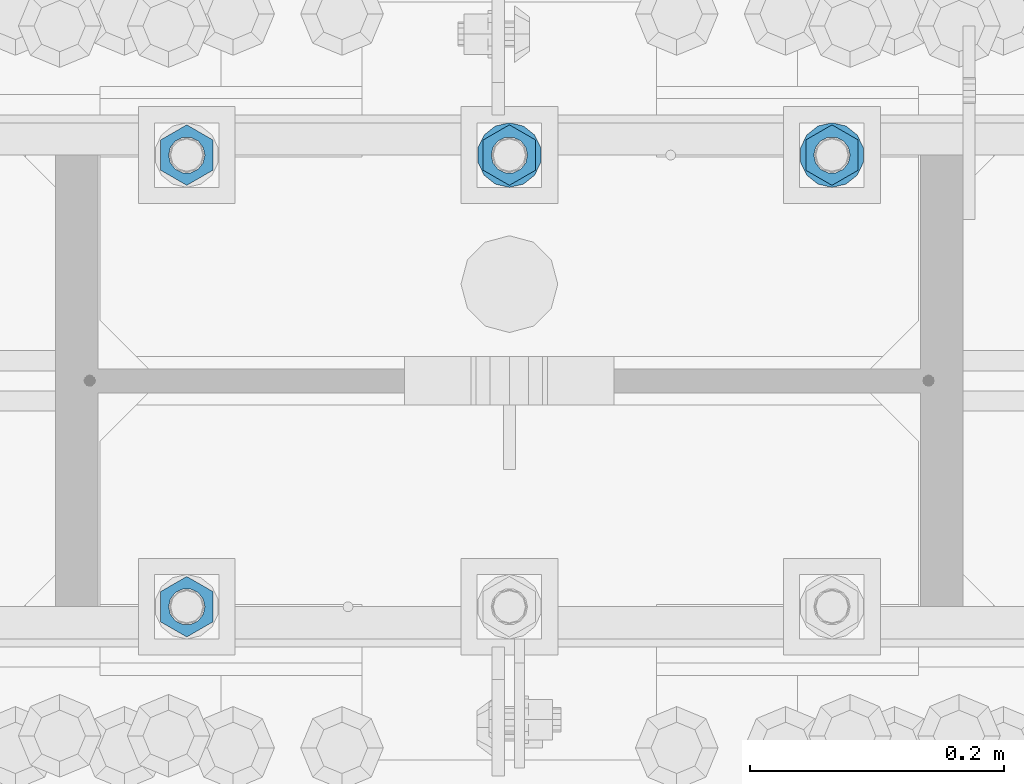
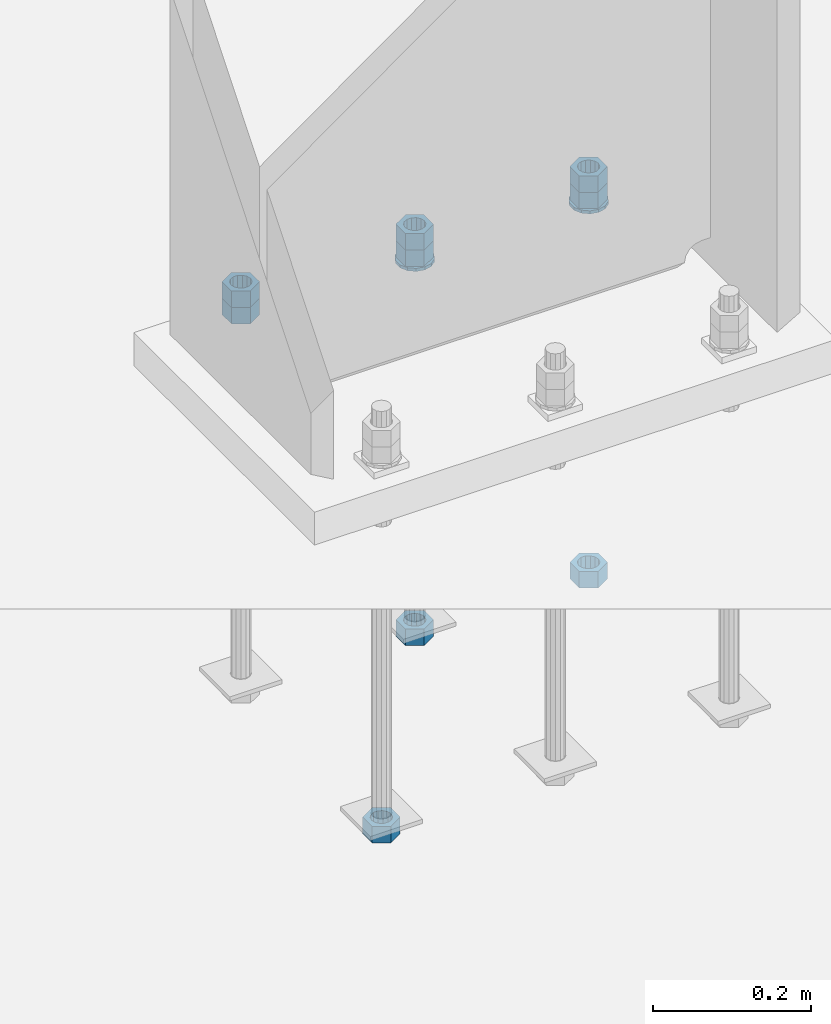
# One storey, part 1023 of 1763: 11 columns, 1 element without a shape of its own.
"""IFC2X3 building model written with IfcOpenShell, lengths in millimetres."""

from ifc_helpers import new_model, si_unit, frame, origin_with_axes, place, context, subcontext, project, spatial, faceted_brep, material, type_object, element, aggregate, save


model = new_model("IFC2X3")

# Units and contexts
model_context = context("Model", 3, precision=1e-05, world=origin_with_axes())
body_context = subcontext(model_context, "Body", "Model", "MODEL_VIEW")
ifc_project = project(units=[si_unit("LENGTHUNIT", "METRE", prefix="MILLI"), si_unit("AREAUNIT", "SQUARE_METRE"), si_unit("VOLUMEUNIT", "CUBIC_METRE"), si_unit("MASSUNIT", "GRAM", prefix="KILO"), si_unit("TIMEUNIT", "SECOND"), si_unit("PLANEANGLEUNIT", "RADIAN"), si_unit("SOLIDANGLEUNIT", "STERADIAN"), si_unit("THERMODYNAMICTEMPERATUREUNIT", "DEGREE_CELSIUS"), si_unit("LUMINOUSINTENSITYUNIT", "LUMEN")], contexts=[model_context])

# Site, building, storey
site_placement = place(None, origin_with_axes())
site = spatial("IfcSite", under=ifc_project, at=site_placement, CompositionType="ELEMENT")
building_placement = place(site_placement, origin_with_axes())
building = spatial("IfcBuilding", under=site, at=building_placement, Name="Undefined", CompositionType="ELEMENT")
storey_placement = place(building_placement, origin_with_axes())
storey = spatial("IfcBuildingStorey", under=building, at=storey_placement, Name="Undefined", CompositionType="ELEMENT", Elevation=0.0)

# Assembly, columns
assembly_placement = place(storey_placement, origin_with_axes())
assembly = element("IfcElementAssembly", 1, at=assembly_placement, inside=storey, Name="TEMPLATE", AssemblyPlace="NOTDEFINED", PredefinedType="RIGID_FRAME")
ifc_material_1 = material(Name="STEEL/A563")
column_type_1 = type_object("IfcColumnType", Name="1_HEAVY_HEX_NUT", PredefinedType="NOTDEFINED")
column_1_placement = place(assembly_placement, frame((-61340.4372736983, 52298.6, -150.812499999996), z_axis=(-1.0, 0.0, 0.0), x_axis=(0.0, 0.0, -1.0)))
column_1 = element("IfcColumn", 2, at=column_1_placement, type_object=column_type_1, material=ifc_material_1, Name="NUT", ObjectType="1_HEAVY_HEX_NUT", context=body_context, shape_type="Brep", body=[
    faceted_brep([(0.0, -23.8099994659424, 0.0), (0.0, -11.9099998474121, -20.6200008392334), (25.4, -11.9099998474121, -20.6200008392334), (25.4, -23.8099994659424, 0.0), (0.0, 11.9099998474121, -20.6200008392334), (25.4, 11.9099998474121, -20.6200008392334), (0.0, 23.8099994659424, 0.0), (25.4, 23.8099994659424, 0.0), (0.0, 11.9099998474121, 20.6200008392334), (25.4, 11.9099998474121, 20.6200008392334), (0.0, -11.9099998474121, 20.6200008392334), (25.4, -11.9099998474121, 20.6200008392334), (0.0, 0.0, 14.289999961853), (0.0, 6.20019861543551, 12.8748450879575), (25.4, 6.20019861543551, 12.8748450879502), (25.4, 0.0, 14.289999961853), (0.0, 11.1723718546418, 8.90966924477834), (25.4, 11.1723718546418, 8.90966924477834), (0.0, 13.9317198278877, 3.17982413774735), (25.4, 13.9317198278877, 3.17982413774007), (0.0, 13.9317198278877, -3.17982413774735), (25.4, 13.9317198278877, -3.17982413774007), (0.0, 11.1723718546418, -8.90966924477834), (25.4, 11.1723718546418, -8.90966924477834), (0.0, 6.20019861543551, -12.8748450879575), (25.4, 6.20019861543551, -12.8748450879502), (0.0, 0.0, -14.289999961853), (25.4, 0.0, -14.289999961853), (0.0, -6.20019861543551, -12.8748450879575), (25.4, -6.20019861543551, -12.8748450879502), (0.0, -11.1723718546418, -8.90966924477834), (25.4, -11.1723718546418, -8.90966924477834), (0.0, -13.9317198278877, -3.17982413774735), (25.4, -13.9317198278877, -3.17982413774007), (0.0, -13.9317198278877, 3.17982413774735), (25.4, -13.9317198278877, 3.17982413774007), (0.0, -11.1723718546418, 8.90966924477834), (25.4, -11.1723718546418, 8.90966924477834), (0.0, -6.20019861543551, 12.8748450879575), (25.4, -6.20019861543551, 12.8748450879502)], [[[0, 1, 2, 3]], [[1, 4, 5, 2]], [[4, 6, 7, 5]], [[6, 8, 9, 7]], [[8, 10, 11, 9]], [[10, 0, 3, 11]], [[12, 13, 14, 15]], [[13, 16, 17, 14]], [[16, 18, 19, 17]], [[18, 20, 21, 19]], [[20, 22, 23, 21]], [[22, 24, 25, 23]], [[24, 26, 27, 25]], [[26, 28, 29, 27]], [[28, 30, 31, 29]], [[30, 32, 33, 31]], [[32, 34, 35, 33]], [[34, 36, 37, 35]], [[36, 38, 39, 37]], [[38, 12, 15, 39]], [[5, 7, 9, 11, 3, 2], [17, 19, 21, 23, 25, 27, 29, 31, 33, 35, 37, 39, 15, 14]], [[10, 8, 6, 4, 1, 0], [38, 36, 34, 32, 30, 28, 26, 24, 22, 20, 18, 16, 13, 12]]]),
])
column_2_placement = place(assembly_placement, frame((-61594.4372736983, 52298.6, -150.812499999996), z_axis=(-1.0, 0.0, 0.0), x_axis=(0.0, 0.0, -1.0)))
column_2 = element("IfcColumn", 3, at=column_2_placement, type_object=column_type_1, material=ifc_material_1, Name="NUT", ObjectType="1_HEAVY_HEX_NUT", context=body_context, shape_type="Brep", body=[
    faceted_brep([(0.0, -23.8099994659424, 0.0), (0.0, -11.9099998474121, -20.6200008392334), (25.4, -11.9099998474121, -20.6200008392334), (25.4, -23.8099994659424, 0.0), (0.0, 11.9099998474121, -20.6200008392334), (25.4, 11.9099998474121, -20.6200008392334), (0.0, 23.8099994659424, 0.0), (25.4, 23.8099994659424, 0.0), (0.0, 11.9099998474121, 20.6200008392334), (25.4, 11.9099998474121, 20.6200008392334), (0.0, -11.9099998474121, 20.6200008392334), (25.4, -11.9099998474121, 20.6200008392334), (0.0, 0.0, 14.289999961853), (0.0, 6.20019861543551, 12.8748450879575), (25.4, 6.20019861543551, 12.8748450879502), (25.4, 0.0, 14.289999961853), (0.0, 11.1723718546418, 8.90966924477834), (25.4, 11.1723718546418, 8.90966924477834), (0.0, 13.9317198278877, 3.17982413774735), (25.4, 13.9317198278877, 3.17982413774007), (0.0, 13.9317198278877, -3.17982413774735), (25.4, 13.9317198278877, -3.17982413774007), (0.0, 11.1723718546418, -8.90966924477834), (25.4, 11.1723718546418, -8.90966924477834), (0.0, 6.20019861543551, -12.8748450879575), (25.4, 6.20019861543551, -12.8748450879502), (0.0, 0.0, -14.289999961853), (25.4, 0.0, -14.289999961853), (0.0, -6.20019861543551, -12.8748450879575), (25.4, -6.20019861543551, -12.8748450879502), (0.0, -11.1723718546418, -8.90966924477834), (25.4, -11.1723718546418, -8.90966924477834), (0.0, -13.9317198278877, -3.17982413774735), (25.4, -13.9317198278877, -3.17982413774007), (0.0, -13.9317198278877, 3.17982413774735), (25.4, -13.9317198278877, 3.17982413774007), (0.0, -11.1723718546418, 8.90966924477834), (25.4, -11.1723718546418, 8.90966924477834), (0.0, -6.20019861543551, 12.8748450879575), (25.4, -6.20019861543551, 12.8748450879502)], [[[0, 1, 2, 3]], [[1, 4, 5, 2]], [[4, 6, 7, 5]], [[6, 8, 9, 7]], [[8, 10, 11, 9]], [[10, 0, 3, 11]], [[12, 13, 14, 15]], [[13, 16, 17, 14]], [[16, 18, 19, 17]], [[18, 20, 21, 19]], [[20, 22, 23, 21]], [[22, 24, 25, 23]], [[24, 26, 27, 25]], [[26, 28, 29, 27]], [[28, 30, 31, 29]], [[30, 32, 33, 31]], [[32, 34, 35, 33]], [[34, 36, 37, 35]], [[36, 38, 39, 37]], [[38, 12, 15, 39]], [[5, 7, 9, 11, 3, 2], [17, 19, 21, 23, 25, 27, 29, 31, 33, 35, 37, 39, 15, 14]], [[10, 8, 6, 4, 1, 0], [38, 36, 34, 32, 30, 28, 26, 24, 22, 20, 18, 16, 13, 12]]]),
])
column_3_placement = place(assembly_placement, frame((-61848.4372736983, 52298.6, -150.812499999996), z_axis=(-1.0, 0.0, 0.0), x_axis=(0.0, 0.0, -1.0)))
column_3 = element("IfcColumn", 4, at=column_3_placement, type_object=column_type_1, material=ifc_material_1, Name="NUT", ObjectType="1_HEAVY_HEX_NUT", context=body_context, shape_type="Brep", body=[
    faceted_brep([(0.0, -23.8099994659424, 0.0), (0.0, -11.9099998474121, -20.6200008392334), (25.4, -11.9099998474121, -20.6200008392334), (25.4, -23.8099994659424, 0.0), (0.0, 11.9099998474121, -20.6200008392334), (25.4, 11.9099998474121, -20.6200008392334), (0.0, 23.8099994659424, 0.0), (25.4, 23.8099994659424, 0.0), (0.0, 11.9099998474121, 20.6200008392334), (25.4, 11.9099998474121, 20.6200008392334), (0.0, -11.9099998474121, 20.6200008392334), (25.4, -11.9099998474121, 20.6200008392334), (0.0, 0.0, 14.289999961853), (0.0, 6.20019861543551, 12.8748450879575), (25.4, 6.20019861543551, 12.8748450879502), (25.4, 0.0, 14.289999961853), (0.0, 11.1723718546418, 8.90966924477834), (25.4, 11.1723718546418, 8.90966924477834), (0.0, 13.9317198278877, 3.17982413774735), (25.4, 13.9317198278877, 3.17982413774007), (0.0, 13.9317198278877, -3.17982413774735), (25.4, 13.9317198278877, -3.17982413774007), (0.0, 11.1723718546418, -8.90966924477834), (25.4, 11.1723718546418, -8.90966924477834), (0.0, 6.20019861543551, -12.8748450879575), (25.4, 6.20019861543551, -12.8748450879502), (0.0, 0.0, -14.289999961853), (25.4, 0.0, -14.289999961853), (0.0, -6.20019861543551, -12.8748450879575), (25.4, -6.20019861543551, -12.8748450879502), (0.0, -11.1723718546418, -8.90966924477834), (25.4, -11.1723718546418, -8.90966924477834), (0.0, -13.9317198278877, -3.17982413774735), (25.4, -13.9317198278877, -3.17982413774007), (0.0, -13.9317198278877, 3.17982413774735), (25.4, -13.9317198278877, 3.17982413774007), (0.0, -11.1723718546418, 8.90966924477834), (25.4, -11.1723718546418, 8.90966924477834), (0.0, -6.20019861543551, 12.8748450879575), (25.4, -6.20019861543551, 12.8748450879502)], [[[0, 1, 2, 3]], [[1, 4, 5, 2]], [[4, 6, 7, 5]], [[6, 8, 9, 7]], [[8, 10, 11, 9]], [[10, 0, 3, 11]], [[12, 13, 14, 15]], [[13, 16, 17, 14]], [[16, 18, 19, 17]], [[18, 20, 21, 19]], [[20, 22, 23, 21]], [[22, 24, 25, 23]], [[24, 26, 27, 25]], [[26, 28, 29, 27]], [[28, 30, 31, 29]], [[30, 32, 33, 31]], [[32, 34, 35, 33]], [[34, 36, 37, 35]], [[36, 38, 39, 37]], [[38, 12, 15, 39]], [[5, 7, 9, 11, 3, 2], [17, 19, 21, 23, 25, 27, 29, 31, 33, 35, 37, 39, 15, 14]], [[10, 8, 6, 4, 1, 0], [38, 36, 34, 32, 30, 28, 26, 24, 22, 20, 18, 16, 13, 12]]]),
])
column_4_placement = place(assembly_placement, frame((-61340.4372736983, 52298.6, -176.212499999996), z_axis=(-1.0, 0.0, 0.0), x_axis=(0.0, 0.0, -1.0)))
column_4 = element("IfcColumn", 5, at=column_4_placement, type_object=column_type_1, material=ifc_material_1, Name="NUT", ObjectType="1_HEAVY_HEX_NUT", context=body_context, shape_type="Brep", body=[
    faceted_brep([(0.0, -23.8099994659424, 0.0), (0.0, -11.9099998474121, -20.6200008392334), (25.4, -11.9099998474121, -20.6200008392334), (25.4, -23.8099994659424, 0.0), (0.0, 11.9099998474121, -20.6200008392334), (25.4, 11.9099998474121, -20.6200008392334), (0.0, 23.8099994659424, 0.0), (25.4, 23.8099994659424, 0.0), (0.0, 11.9099998474121, 20.6200008392334), (25.4, 11.9099998474121, 20.6200008392334), (0.0, -11.9099998474121, 20.6200008392334), (25.4, -11.9099998474121, 20.6200008392334), (0.0, 0.0, 14.289999961853), (0.0, 6.20019861543551, 12.8748450879575), (25.4, 6.20019861543551, 12.8748450879502), (25.4, 0.0, 14.289999961853), (0.0, 11.1723718546418, 8.90966924477834), (25.4, 11.1723718546418, 8.90966924477834), (0.0, 13.9317198278877, 3.17982413774735), (25.4, 13.9317198278877, 3.17982413774007), (0.0, 13.9317198278877, -3.17982413774735), (25.4, 13.9317198278877, -3.17982413774007), (0.0, 11.1723718546418, -8.90966924477834), (25.4, 11.1723718546418, -8.90966924477834), (0.0, 6.20019861543551, -12.8748450879575), (25.4, 6.20019861543551, -12.8748450879502), (0.0, 0.0, -14.289999961853), (25.4, 0.0, -14.289999961853), (0.0, -6.20019861543551, -12.8748450879575), (25.4, -6.20019861543551, -12.8748450879502), (0.0, -11.1723718546418, -8.90966924477834), (25.4, -11.1723718546418, -8.90966924477834), (0.0, -13.9317198278877, -3.17982413774735), (25.4, -13.9317198278877, -3.17982413774007), (0.0, -13.9317198278877, 3.17982413774735), (25.4, -13.9317198278877, 3.17982413774007), (0.0, -11.1723718546418, 8.90966924477834), (25.4, -11.1723718546418, 8.90966924477834), (0.0, -6.20019861543551, 12.8748450879575), (25.4, -6.20019861543551, 12.8748450879502)], [[[0, 1, 2, 3]], [[1, 4, 5, 2]], [[4, 6, 7, 5]], [[6, 8, 9, 7]], [[8, 10, 11, 9]], [[10, 0, 3, 11]], [[12, 13, 14, 15]], [[13, 16, 17, 14]], [[16, 18, 19, 17]], [[18, 20, 21, 19]], [[20, 22, 23, 21]], [[22, 24, 25, 23]], [[24, 26, 27, 25]], [[26, 28, 29, 27]], [[28, 30, 31, 29]], [[30, 32, 33, 31]], [[32, 34, 35, 33]], [[34, 36, 37, 35]], [[36, 38, 39, 37]], [[38, 12, 15, 39]], [[5, 7, 9, 11, 3, 2], [17, 19, 21, 23, 25, 27, 29, 31, 33, 35, 37, 39, 15, 14]], [[10, 8, 6, 4, 1, 0], [38, 36, 34, 32, 30, 28, 26, 24, 22, 20, 18, 16, 13, 12]]]),
])
column_5_placement = place(assembly_placement, frame((-61340.4372736983, 52298.6, -761.999999999996), z_axis=(-1.0, 0.0, 0.0), x_axis=(0.0, 0.0, -1.0)))
column_5 = element("IfcColumn", 6, at=column_5_placement, type_object=column_type_1, material=ifc_material_1, Name="NUT", ObjectType="1_HEAVY_HEX_NUT", context=body_context, shape_type="Brep", body=[
    faceted_brep([(0.0, -23.8099994659424, 0.0), (0.0, -11.9099998474121, -20.6200008392334), (25.4, -11.9099998474121, -20.6200008392334), (25.4, -23.8099994659424, 0.0), (0.0, 11.9099998474121, -20.6200008392334), (25.4, 11.9099998474121, -20.6200008392334), (0.0, 23.8099994659424, 0.0), (25.4, 23.8099994659424, 0.0), (0.0, 11.9099998474121, 20.6200008392334), (25.4, 11.9099998474121, 20.6200008392334), (0.0, -11.9099998474121, 20.6200008392334), (25.4, -11.9099998474121, 20.6200008392334), (0.0, 0.0, 14.289999961853), (0.0, 6.20019861543551, 12.8748450879575), (25.4, 6.20019861543551, 12.8748450879502), (25.4, 0.0, 14.289999961853), (0.0, 11.1723718546418, 8.90966924477834), (25.4, 11.1723718546418, 8.90966924477834), (0.0, 13.9317198278877, 3.17982413774735), (25.4, 13.9317198278877, 3.17982413774007), (0.0, 13.9317198278877, -3.17982413774735), (25.4, 13.9317198278877, -3.17982413774007), (0.0, 11.1723718546418, -8.90966924477834), (25.4, 11.1723718546418, -8.90966924477834), (0.0, 6.20019861543551, -12.8748450879575), (25.4, 6.20019861543551, -12.8748450879502), (0.0, 0.0, -14.289999961853), (25.4, 0.0, -14.289999961853), (0.0, -6.20019861543551, -12.8748450879575), (25.4, -6.20019861543551, -12.8748450879502), (0.0, -11.1723718546418, -8.90966924477834), (25.4, -11.1723718546418, -8.90966924477834), (0.0, -13.9317198278877, -3.17982413774735), (25.4, -13.9317198278877, -3.17982413774007), (0.0, -13.9317198278877, 3.17982413774735), (25.4, -13.9317198278877, 3.17982413774007), (0.0, -11.1723718546418, 8.90966924477834), (25.4, -11.1723718546418, 8.90966924477834), (0.0, -6.20019861543551, 12.8748450879575), (25.4, -6.20019861543551, 12.8748450879502)], [[[0, 1, 2, 3]], [[1, 4, 5, 2]], [[4, 6, 7, 5]], [[6, 8, 9, 7]], [[8, 10, 11, 9]], [[10, 0, 3, 11]], [[12, 13, 14, 15]], [[13, 16, 17, 14]], [[16, 18, 19, 17]], [[18, 20, 21, 19]], [[20, 22, 23, 21]], [[22, 24, 25, 23]], [[24, 26, 27, 25]], [[26, 28, 29, 27]], [[28, 30, 31, 29]], [[30, 32, 33, 31]], [[32, 34, 35, 33]], [[34, 36, 37, 35]], [[36, 38, 39, 37]], [[38, 12, 15, 39]], [[5, 7, 9, 11, 3, 2], [17, 19, 21, 23, 25, 27, 29, 31, 33, 35, 37, 39, 15, 14]], [[10, 8, 6, 4, 1, 0], [38, 36, 34, 32, 30, 28, 26, 24, 22, 20, 18, 16, 13, 12]]]),
])
column_6_placement = place(assembly_placement, frame((-61594.4372736983, 52298.6, -176.212499999996), z_axis=(-1.0, 0.0, 0.0), x_axis=(0.0, 0.0, -1.0)))
column_6 = element("IfcColumn", 7, at=column_6_placement, type_object=column_type_1, material=ifc_material_1, Name="NUT", ObjectType="1_HEAVY_HEX_NUT", context=body_context, shape_type="Brep", body=[
    faceted_brep([(0.0, -23.8099994659424, 0.0), (0.0, -11.9099998474121, -20.6200008392334), (25.4, -11.9099998474121, -20.6200008392334), (25.4, -23.8099994659424, 0.0), (0.0, 11.9099998474121, -20.6200008392334), (25.4, 11.9099998474121, -20.6200008392334), (0.0, 23.8099994659424, 0.0), (25.4, 23.8099994659424, 0.0), (0.0, 11.9099998474121, 20.6200008392334), (25.4, 11.9099998474121, 20.6200008392334), (0.0, -11.9099998474121, 20.6200008392334), (25.4, -11.9099998474121, 20.6200008392334), (0.0, 0.0, 14.289999961853), (0.0, 6.20019861543551, 12.8748450879575), (25.4, 6.20019861543551, 12.8748450879502), (25.4, 0.0, 14.289999961853), (0.0, 11.1723718546418, 8.90966924477834), (25.4, 11.1723718546418, 8.90966924477834), (0.0, 13.9317198278877, 3.17982413774735), (25.4, 13.9317198278877, 3.17982413774007), (0.0, 13.9317198278877, -3.17982413774735), (25.4, 13.9317198278877, -3.17982413774007), (0.0, 11.1723718546418, -8.90966924477834), (25.4, 11.1723718546418, -8.90966924477834), (0.0, 6.20019861543551, -12.8748450879575), (25.4, 6.20019861543551, -12.8748450879502), (0.0, 0.0, -14.289999961853), (25.4, 0.0, -14.289999961853), (0.0, -6.20019861543551, -12.8748450879575), (25.4, -6.20019861543551, -12.8748450879502), (0.0, -11.1723718546418, -8.90966924477834), (25.4, -11.1723718546418, -8.90966924477834), (0.0, -13.9317198278877, -3.17982413774735), (25.4, -13.9317198278877, -3.17982413774007), (0.0, -13.9317198278877, 3.17982413774735), (25.4, -13.9317198278877, 3.17982413774007), (0.0, -11.1723718546418, 8.90966924477834), (25.4, -11.1723718546418, 8.90966924477834), (0.0, -6.20019861543551, 12.8748450879575), (25.4, -6.20019861543551, 12.8748450879502)], [[[0, 1, 2, 3]], [[1, 4, 5, 2]], [[4, 6, 7, 5]], [[6, 8, 9, 7]], [[8, 10, 11, 9]], [[10, 0, 3, 11]], [[12, 13, 14, 15]], [[13, 16, 17, 14]], [[16, 18, 19, 17]], [[18, 20, 21, 19]], [[20, 22, 23, 21]], [[22, 24, 25, 23]], [[24, 26, 27, 25]], [[26, 28, 29, 27]], [[28, 30, 31, 29]], [[30, 32, 33, 31]], [[32, 34, 35, 33]], [[34, 36, 37, 35]], [[36, 38, 39, 37]], [[38, 12, 15, 39]], [[5, 7, 9, 11, 3, 2], [17, 19, 21, 23, 25, 27, 29, 31, 33, 35, 37, 39, 15, 14]], [[10, 8, 6, 4, 1, 0], [38, 36, 34, 32, 30, 28, 26, 24, 22, 20, 18, 16, 13, 12]]]),
])
column_7_placement = place(assembly_placement, frame((-61594.4372736983, 52298.6, -761.999999999996), z_axis=(-1.0, 0.0, 0.0), x_axis=(0.0, 0.0, -1.0)))
column_7 = element("IfcColumn", 8, at=column_7_placement, type_object=column_type_1, material=ifc_material_1, Name="NUT", ObjectType="1_HEAVY_HEX_NUT", context=body_context, shape_type="Brep", body=[
    faceted_brep([(0.0, -23.8099994659424, 0.0), (0.0, -11.9099998474121, -20.6200008392334), (25.4, -11.9099998474121, -20.6200008392334), (25.4, -23.8099994659424, 0.0), (0.0, 11.9099998474121, -20.6200008392334), (25.4, 11.9099998474121, -20.6200008392334), (0.0, 23.8099994659424, 0.0), (25.4, 23.8099994659424, 0.0), (0.0, 11.9099998474121, 20.6200008392334), (25.4, 11.9099998474121, 20.6200008392334), (0.0, -11.9099998474121, 20.6200008392334), (25.4, -11.9099998474121, 20.6200008392334), (0.0, 0.0, 14.289999961853), (0.0, 6.20019861543551, 12.8748450879575), (25.4, 6.20019861543551, 12.8748450879502), (25.4, 0.0, 14.289999961853), (0.0, 11.1723718546418, 8.90966924477834), (25.4, 11.1723718546418, 8.90966924477834), (0.0, 13.9317198278877, 3.17982413774735), (25.4, 13.9317198278877, 3.17982413774007), (0.0, 13.9317198278877, -3.17982413774735), (25.4, 13.9317198278877, -3.17982413774007), (0.0, 11.1723718546418, -8.90966924477834), (25.4, 11.1723718546418, -8.90966924477834), (0.0, 6.20019861543551, -12.8748450879575), (25.4, 6.20019861543551, -12.8748450879502), (0.0, 0.0, -14.289999961853), (25.4, 0.0, -14.289999961853), (0.0, -6.20019861543551, -12.8748450879575), (25.4, -6.20019861543551, -12.8748450879502), (0.0, -11.1723718546418, -8.90966924477834), (25.4, -11.1723718546418, -8.90966924477834), (0.0, -13.9317198278877, -3.17982413774735), (25.4, -13.9317198278877, -3.17982413774007), (0.0, -13.9317198278877, 3.17982413774735), (25.4, -13.9317198278877, 3.17982413774007), (0.0, -11.1723718546418, 8.90966924477834), (25.4, -11.1723718546418, 8.90966924477834), (0.0, -6.20019861543551, 12.8748450879575), (25.4, -6.20019861543551, 12.8748450879502)], [[[0, 1, 2, 3]], [[1, 4, 5, 2]], [[4, 6, 7, 5]], [[6, 8, 9, 7]], [[8, 10, 11, 9]], [[10, 0, 3, 11]], [[12, 13, 14, 15]], [[13, 16, 17, 14]], [[16, 18, 19, 17]], [[18, 20, 21, 19]], [[20, 22, 23, 21]], [[22, 24, 25, 23]], [[24, 26, 27, 25]], [[26, 28, 29, 27]], [[28, 30, 31, 29]], [[30, 32, 33, 31]], [[32, 34, 35, 33]], [[34, 36, 37, 35]], [[36, 38, 39, 37]], [[38, 12, 15, 39]], [[5, 7, 9, 11, 3, 2], [17, 19, 21, 23, 25, 27, 29, 31, 33, 35, 37, 39, 15, 14]], [[10, 8, 6, 4, 1, 0], [38, 36, 34, 32, 30, 28, 26, 24, 22, 20, 18, 16, 13, 12]]]),
])
column_8_placement = place(assembly_placement, frame((-61848.4372736983, 51943.0, -761.999999999996), z_axis=(1.0, 0.0, 0.0), x_axis=(0.0, 0.0, -1.0)))
column_8 = element("IfcColumn", 9, at=column_8_placement, type_object=column_type_1, material=ifc_material_1, Name="NUT", ObjectType="1_HEAVY_HEX_NUT", context=body_context, shape_type="Brep", body=[
    faceted_brep([(0.0, -23.8099994659424, 0.0), (0.0, -11.9099998474121, -20.6200008392334), (25.4, -11.9099998474121, -20.6200008392334), (25.4, -23.8099994659424, 0.0), (0.0, 11.9099998474121, -20.6200008392334), (25.4, 11.9099998474121, -20.6200008392334), (0.0, 23.8099994659424, 0.0), (25.4, 23.8099994659424, 0.0), (0.0, 11.9099998474121, 20.6200008392334), (25.4, 11.9099998474121, 20.6200008392334), (0.0, -11.9099998474121, 20.6200008392334), (25.4, -11.9099998474121, 20.6200008392334), (0.0, 0.0, 14.289999961853), (0.0, 6.20019861543551, 12.8748450879575), (25.4, 6.20019861543551, 12.8748450879502), (25.4, 0.0, 14.289999961853), (0.0, 11.1723718546418, 8.90966924477834), (25.4, 11.1723718546418, 8.90966924477834), (0.0, 13.9317198278877, 3.17982413774735), (25.4, 13.9317198278877, 3.17982413774007), (0.0, 13.9317198278877, -3.17982413774735), (25.4, 13.9317198278877, -3.17982413774007), (0.0, 11.1723718546418, -8.90966924477834), (25.4, 11.1723718546418, -8.90966924477834), (0.0, 6.20019861543551, -12.8748450879575), (25.4, 6.20019861543551, -12.8748450879502), (0.0, 0.0, -14.289999961853), (25.4, 0.0, -14.289999961853), (0.0, -6.20019861543551, -12.8748450879575), (25.4, -6.20019861543551, -12.8748450879502), (0.0, -11.1723718546418, -8.90966924477834), (25.4, -11.1723718546418, -8.90966924477834), (0.0, -13.9317198278877, -3.17982413774735), (25.4, -13.9317198278877, -3.17982413774007), (0.0, -13.9317198278877, 3.17982413774735), (25.4, -13.9317198278877, 3.17982413774007), (0.0, -11.1723718546418, 8.90966924477834), (25.4, -11.1723718546418, 8.90966924477834), (0.0, -6.20019861543551, 12.8748450879575), (25.4, -6.20019861543551, 12.8748450879502)], [[[0, 1, 2, 3]], [[1, 4, 5, 2]], [[4, 6, 7, 5]], [[6, 8, 9, 7]], [[8, 10, 11, 9]], [[10, 0, 3, 11]], [[12, 13, 14, 15]], [[13, 16, 17, 14]], [[16, 18, 19, 17]], [[18, 20, 21, 19]], [[20, 22, 23, 21]], [[22, 24, 25, 23]], [[24, 26, 27, 25]], [[26, 28, 29, 27]], [[28, 30, 31, 29]], [[30, 32, 33, 31]], [[32, 34, 35, 33]], [[34, 36, 37, 35]], [[36, 38, 39, 37]], [[38, 12, 15, 39]], [[5, 7, 9, 11, 3, 2], [17, 19, 21, 23, 25, 27, 29, 31, 33, 35, 37, 39, 15, 14]], [[10, 8, 6, 4, 1, 0], [38, 36, 34, 32, 30, 28, 26, 24, 22, 20, 18, 16, 13, 12]]]),
])
column_9_placement = place(assembly_placement, frame((-61848.4372736983, 52298.6, -176.212499999996), z_axis=(-1.0, 0.0, 0.0), x_axis=(0.0, 0.0, -1.0)))
column_9 = element("IfcColumn", 10, at=column_9_placement, type_object=column_type_1, material=ifc_material_1, Name="NUT", ObjectType="1_HEAVY_HEX_NUT", context=body_context, shape_type="Brep", body=[
    faceted_brep([(0.0, -23.8099994659424, 0.0), (0.0, -11.9099998474121, -20.6200008392334), (25.4, -11.9099998474121, -20.6200008392334), (25.4, -23.8099994659424, 0.0), (0.0, 11.9099998474121, -20.6200008392334), (25.4, 11.9099998474121, -20.6200008392334), (0.0, 23.8099994659424, 0.0), (25.4, 23.8099994659424, 0.0), (0.0, 11.9099998474121, 20.6200008392334), (25.4, 11.9099998474121, 20.6200008392334), (0.0, -11.9099998474121, 20.6200008392334), (25.4, -11.9099998474121, 20.6200008392334), (0.0, 0.0, 14.289999961853), (0.0, 6.20019861543551, 12.8748450879575), (25.4, 6.20019861543551, 12.8748450879502), (25.4, 0.0, 14.289999961853), (0.0, 11.1723718546418, 8.90966924477834), (25.4, 11.1723718546418, 8.90966924477834), (0.0, 13.9317198278877, 3.17982413774735), (25.4, 13.9317198278877, 3.17982413774007), (0.0, 13.9317198278877, -3.17982413774735), (25.4, 13.9317198278877, -3.17982413774007), (0.0, 11.1723718546418, -8.90966924477834), (25.4, 11.1723718546418, -8.90966924477834), (0.0, 6.20019861543551, -12.8748450879575), (25.4, 6.20019861543551, -12.8748450879502), (0.0, 0.0, -14.289999961853), (25.4, 0.0, -14.289999961853), (0.0, -6.20019861543551, -12.8748450879575), (25.4, -6.20019861543551, -12.8748450879502), (0.0, -11.1723718546418, -8.90966924477834), (25.4, -11.1723718546418, -8.90966924477834), (0.0, -13.9317198278877, -3.17982413774735), (25.4, -13.9317198278877, -3.17982413774007), (0.0, -13.9317198278877, 3.17982413774735), (25.4, -13.9317198278877, 3.17982413774007), (0.0, -11.1723718546418, 8.90966924477834), (25.4, -11.1723718546418, 8.90966924477834), (0.0, -6.20019861543551, 12.8748450879575), (25.4, -6.20019861543551, 12.8748450879502)], [[[0, 1, 2, 3]], [[1, 4, 5, 2]], [[4, 6, 7, 5]], [[6, 8, 9, 7]], [[8, 10, 11, 9]], [[10, 0, 3, 11]], [[12, 13, 14, 15]], [[13, 16, 17, 14]], [[16, 18, 19, 17]], [[18, 20, 21, 19]], [[20, 22, 23, 21]], [[22, 24, 25, 23]], [[24, 26, 27, 25]], [[26, 28, 29, 27]], [[28, 30, 31, 29]], [[30, 32, 33, 31]], [[32, 34, 35, 33]], [[34, 36, 37, 35]], [[36, 38, 39, 37]], [[38, 12, 15, 39]], [[5, 7, 9, 11, 3, 2], [17, 19, 21, 23, 25, 27, 29, 31, 33, 35, 37, 39, 15, 14]], [[10, 8, 6, 4, 1, 0], [38, 36, 34, 32, 30, 28, 26, 24, 22, 20, 18, 16, 13, 12]]]),
])
ifc_material_2 = material(Name="STEEL/F436")
column_type_2 = type_object("IfcColumnType", Name="1_WASHER", PredefinedType="NOTDEFINED")
column_10_placement = place(assembly_placement, frame((-61340.4372736983, 52298.6, -201.612499999996), z_axis=(-1.0, 0.0, 0.0), x_axis=(0.0, 0.0, -1.0)))
column_10 = element("IfcColumn", 11, at=column_10_placement, type_object=column_type_2, material=ifc_material_2, Name="WASHER", ObjectType="1_WASHER", context=body_context, shape_type="Brep", body=[
    faceted_brep([(0.0, -25.4000000000015, 0.0), (0.0, -22.8846089010258, -11.0206468080723), (4.76249999999982, -22.8846089010258, -11.0206468080723), (4.76249999999982, -25.3999996185303, 0.0), (0.0, -15.8366407293724, -19.8585193564359), (4.76249999999982, -15.8366407293724, -19.8585193564359), (0.0, -5.65203163760452, -24.7631685975066), (4.76249999999982, -5.65203163760452, -24.7631685975066), (0.0, 5.65203163760452, -24.7631685975066), (4.76249999999982, 5.65203163760452, -24.7631685975066), (0.0, 15.8366407293724, -19.8585193564359), (4.76249999999982, 15.8366407293724, -19.8585193564359), (0.0, 22.8846089010258, -11.0206468080723), (4.76249999999982, 22.8846089010258, -11.0206468080723), (0.0, 25.4000000000015, 0.0), (4.76249999999982, 25.3999996185303, 0.0), (0.0, 22.8846089010258, 11.0206468080723), (4.76249999999982, 22.8846089010258, 11.0206468080723), (0.0, 15.8366407293724, 19.8585193564359), (4.76249999999982, 15.8366407293724, 19.8585193564359), (0.0, 5.65203163760452, 24.7631685975066), (4.76249999999982, 5.65203163760452, 24.7631685975066), (0.0, -5.65203163760452, 24.7631685975066), (4.76249999999982, -5.65203163760452, 24.7631685975066), (0.0, -15.8366407293724, 19.8585193564359), (4.76249999999982, -15.8366407293724, 19.8585193564359), (0.0, -22.8846089010258, 11.0206468080723), (4.76249999999982, -22.8846089010258, 11.0206468080723), (0.0, 0.0, 14.289999961853), (0.0, 6.20019861543551, 12.8748450879575), (4.76249999999982, 6.20019861543551, 12.8748450879502), (4.76249999999982, 0.0, 14.289999961853), (0.0, 11.1723718546418, 8.90966924477834), (4.76249999999982, 11.1723718546418, 8.90966924477834), (0.0, 13.9317198278877, 3.17982413774735), (4.76249999999982, 13.9317198278877, 3.17982413774007), (0.0, 13.9317198278877, -3.17982413774735), (4.76249999999982, 13.9317198278877, -3.17982413774007), (0.0, 11.1723718546418, -8.90966924477834), (4.76249999999982, 11.1723718546418, -8.90966924477834), (0.0, 6.20019861543551, -12.8748450879575), (4.76249999999982, 6.20019861543551, -12.8748450879502), (0.0, 0.0, -14.289999961853), (4.76249999999982, 0.0, -14.289999961853), (0.0, -6.20019861543551, -12.8748450879575), (4.76249999999982, -6.20019861543551, -12.8748450879502), (0.0, -11.1723718546418, -8.90966924477834), (4.76249999999982, -11.1723718546418, -8.90966924477834), (0.0, -13.9317198278877, -3.17982413774735), (4.76249999999982, -13.9317198278877, -3.17982413774007), (0.0, -13.9317198278877, 3.17982413774735), (4.76249999999982, -13.9317198278877, 3.17982413774007), (0.0, -11.1723718546418, 8.90966924477834), (4.76249999999982, -11.1723718546418, 8.90966924477834), (0.0, -6.20019861543551, 12.8748450879575), (4.76249999999982, -6.20019861543551, 12.8748450879502)], [[[0, 1, 2, 3]], [[1, 4, 5, 2]], [[4, 6, 7, 5]], [[6, 8, 9, 7]], [[8, 10, 11, 9]], [[10, 12, 13, 11]], [[12, 14, 15, 13]], [[14, 16, 17, 15]], [[16, 18, 19, 17]], [[18, 20, 21, 19]], [[20, 22, 23, 21]], [[22, 24, 25, 23]], [[24, 26, 27, 25]], [[26, 0, 3, 27]], [[28, 29, 30, 31]], [[29, 32, 33, 30]], [[32, 34, 35, 33]], [[34, 36, 37, 35]], [[36, 38, 39, 37]], [[38, 40, 41, 39]], [[40, 42, 43, 41]], [[42, 44, 45, 43]], [[44, 46, 47, 45]], [[46, 48, 49, 47]], [[48, 50, 51, 49]], [[50, 52, 53, 51]], [[52, 54, 55, 53]], [[54, 28, 31, 55]], [[5, 7, 9, 11, 13, 15, 17, 19, 21, 23, 25, 27, 3, 2], [33, 35, 37, 39, 41, 43, 45, 47, 49, 51, 53, 55, 31, 30]], [[26, 24, 22, 20, 18, 16, 14, 12, 10, 8, 6, 4, 1, 0], [54, 52, 50, 48, 46, 44, 42, 40, 38, 36, 34, 32, 29, 28]]]),
])
column_11_placement = place(assembly_placement, frame((-61594.4372736983, 52298.6, -201.612499999996), z_axis=(-1.0, 0.0, 0.0), x_axis=(0.0, 0.0, -1.0)))
column_11 = element("IfcColumn", 12, at=column_11_placement, type_object=column_type_2, material=ifc_material_2, Name="WASHER", ObjectType="1_WASHER", context=body_context, shape_type="Brep", body=[
    faceted_brep([(0.0, -25.4000000000015, 0.0), (0.0, -22.8846089010258, -11.0206468080723), (4.76249999999982, -22.8846089010258, -11.0206468080723), (4.76249999999982, -25.3999996185303, 0.0), (0.0, -15.8366407293724, -19.8585193564359), (4.76249999999982, -15.8366407293724, -19.8585193564359), (0.0, -5.65203163760452, -24.7631685975066), (4.76249999999982, -5.65203163760452, -24.7631685975066), (0.0, 5.65203163760452, -24.7631685975066), (4.76249999999982, 5.65203163760452, -24.7631685975066), (0.0, 15.8366407293724, -19.8585193564359), (4.76249999999982, 15.8366407293724, -19.8585193564359), (0.0, 22.8846089010258, -11.0206468080723), (4.76249999999982, 22.8846089010258, -11.0206468080723), (0.0, 25.4000000000015, 0.0), (4.76249999999982, 25.3999996185303, 0.0), (0.0, 22.8846089010258, 11.0206468080723), (4.76249999999982, 22.8846089010258, 11.0206468080723), (0.0, 15.8366407293724, 19.8585193564359), (4.76249999999982, 15.8366407293724, 19.8585193564359), (0.0, 5.65203163760452, 24.7631685975066), (4.76249999999982, 5.65203163760452, 24.7631685975066), (0.0, -5.65203163760452, 24.7631685975066), (4.76249999999982, -5.65203163760452, 24.7631685975066), (0.0, -15.8366407293724, 19.8585193564359), (4.76249999999982, -15.8366407293724, 19.8585193564359), (0.0, -22.8846089010258, 11.0206468080723), (4.76249999999982, -22.8846089010258, 11.0206468080723), (0.0, 0.0, 14.289999961853), (0.0, 6.20019861543551, 12.8748450879575), (4.76249999999982, 6.20019861543551, 12.8748450879502), (4.76249999999982, 0.0, 14.289999961853), (0.0, 11.1723718546418, 8.90966924477834), (4.76249999999982, 11.1723718546418, 8.90966924477834), (0.0, 13.9317198278877, 3.17982413774735), (4.76249999999982, 13.9317198278877, 3.17982413774007), (0.0, 13.9317198278877, -3.17982413774735), (4.76249999999982, 13.9317198278877, -3.17982413774007), (0.0, 11.1723718546418, -8.90966924477834), (4.76249999999982, 11.1723718546418, -8.90966924477834), (0.0, 6.20019861543551, -12.8748450879575), (4.76249999999982, 6.20019861543551, -12.8748450879502), (0.0, 0.0, -14.289999961853), (4.76249999999982, 0.0, -14.289999961853), (0.0, -6.20019861543551, -12.8748450879575), (4.76249999999982, -6.20019861543551, -12.8748450879502), (0.0, -11.1723718546418, -8.90966924477834), (4.76249999999982, -11.1723718546418, -8.90966924477834), (0.0, -13.9317198278877, -3.17982413774735), (4.76249999999982, -13.9317198278877, -3.17982413774007), (0.0, -13.9317198278877, 3.17982413774735), (4.76249999999982, -13.9317198278877, 3.17982413774007), (0.0, -11.1723718546418, 8.90966924477834), (4.76249999999982, -11.1723718546418, 8.90966924477834), (0.0, -6.20019861543551, 12.8748450879575), (4.76249999999982, -6.20019861543551, 12.8748450879502)], [[[0, 1, 2, 3]], [[1, 4, 5, 2]], [[4, 6, 7, 5]], [[6, 8, 9, 7]], [[8, 10, 11, 9]], [[10, 12, 13, 11]], [[12, 14, 15, 13]], [[14, 16, 17, 15]], [[16, 18, 19, 17]], [[18, 20, 21, 19]], [[20, 22, 23, 21]], [[22, 24, 25, 23]], [[24, 26, 27, 25]], [[26, 0, 3, 27]], [[28, 29, 30, 31]], [[29, 32, 33, 30]], [[32, 34, 35, 33]], [[34, 36, 37, 35]], [[36, 38, 39, 37]], [[38, 40, 41, 39]], [[40, 42, 43, 41]], [[42, 44, 45, 43]], [[44, 46, 47, 45]], [[46, 48, 49, 47]], [[48, 50, 51, 49]], [[50, 52, 53, 51]], [[52, 54, 55, 53]], [[54, 28, 31, 55]], [[5, 7, 9, 11, 13, 15, 17, 19, 21, 23, 25, 27, 3, 2], [33, 35, 37, 39, 41, 43, 45, 47, 49, 51, 53, 55, 31, 30]], [[26, 24, 22, 20, 18, 16, 14, 12, 10, 8, 6, 4, 1, 0], [54, 52, 50, 48, 46, 44, 42, 40, 38, 36, 34, 32, 29, 28]]]),
])
aggregate(assembly, [column_1, column_2, column_3, column_4, column_10, column_5, column_6, column_11, column_7, column_8, column_9])

save(model, "model.ifc")
